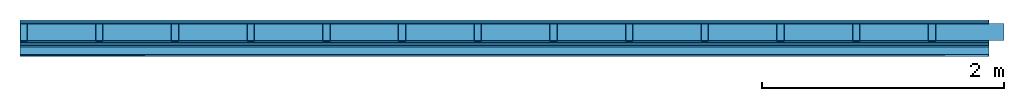
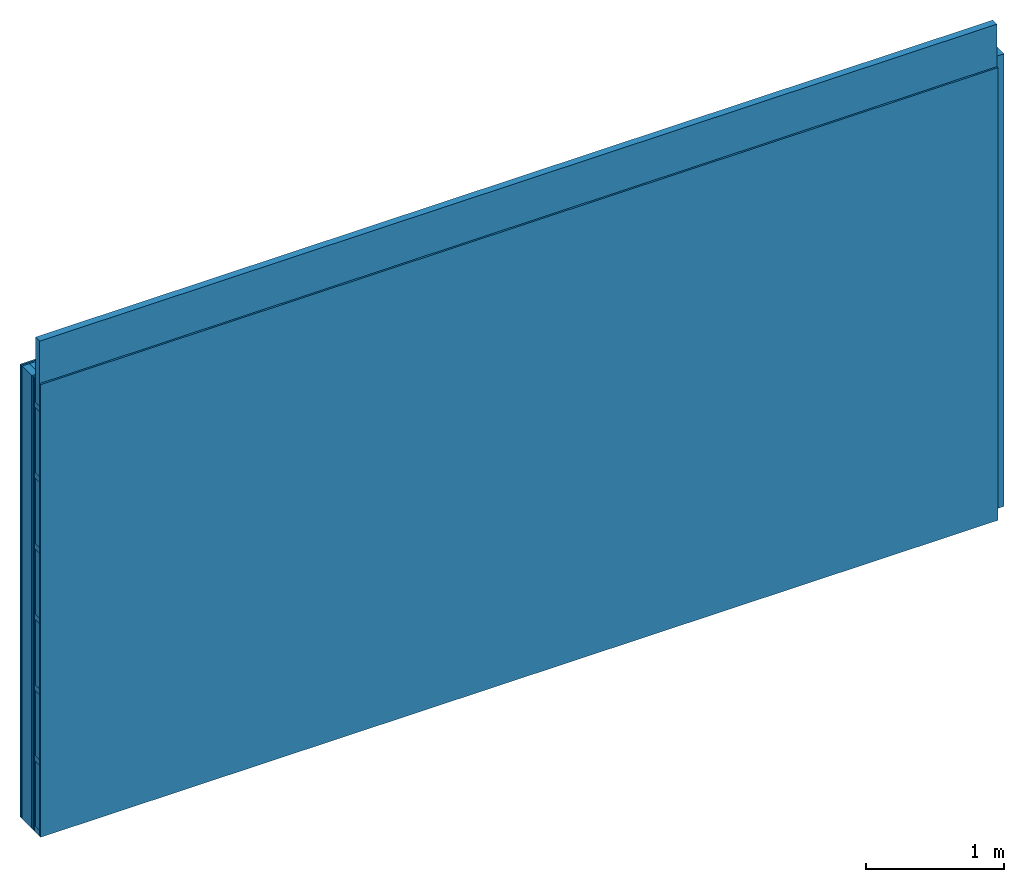
# One storey: 6 plates, 4 members, 1 element without a shape of its own.
"""IFC4 building model written with IfcOpenShell, lengths in metres."""

from ifc_helpers import new_model, si_unit, derived_unit, direction, frame, frame_2d, origin, origin_with_axes, place, context, project, spatial, rectangle, extrude, material, layer, layer_set, type_object, element, aggregate, save


model = new_model("IFC4")

# Units and contexts
plan_context = context("Plan", 3, precision=1e-05, world=origin(), true_north=direction((0.0, 1.0)))
model_context = context("Model", 3, precision=1e-05, world=origin(), true_north=direction((0.0, 1.0)))
ifc_project = project(units=[si_unit("LENGTHUNIT", "METRE"), derived_unit("SOUNDPRESSUREUNIT", [(si_unit("PRESSUREUNIT", "PASCAL", prefix="MICRO"), 0)]), si_unit("ENERGYUNIT", "JOULE", prefix="MEGA"), si_unit("MASSUNIT", "GRAM", prefix="KILO"), derived_unit("THERMALTRANSMITTANCEUNIT", [(si_unit("POWERUNIT", "WATT"), 1), (si_unit("AREAUNIT", "SQUARE_METRE"), -1), (si_unit("THERMODYNAMICTEMPERATUREUNIT", "KELVIN"), -1)]), derived_unit("AREADENSITYUNIT", [(si_unit("MASSUNIT", "GRAM", prefix="KILO"), 1), (si_unit("AREAUNIT", "SQUARE_METRE"), -1)]), derived_unit("USERDEFINED", [(si_unit("ENERGYUNIT", "JOULE", prefix="MEGA"), 1), (si_unit("AREAUNIT", "SQUARE_METRE"), -1)])], contexts=[plan_context, model_context])

# Site, building, storey
site = spatial("IfcSite", under=ifc_project)
building_placement = place(None, origin())
building = spatial("IfcBuilding", under=site, at=building_placement)
storey_placement = place(building_placement, origin())
storey = spatial("IfcBuildingStorey", under=building, at=storey_placement)

# Wall, members, plates
ifc_material_1 = material(Name="Glued joints")
ifc_layer_1 = layer(ifc_material_1, 0.0, Name="Surface")
ifc_material_2 = material(Category="03.007")
ifc_layer_2 = layer(ifc_material_2, 0.015, Name="2nd layer")
ifc_layer_3 = layer(ifc_material_2, 0.015, Name="1st layer")
ifc_material_3 = material(Name="of the art")
ifc_layer_4 = layer(ifc_material_3, 0.0, Name="Bond")
ifc_layer_5 = layer(None, 0.14, Name="Support")
ifc_layer_6 = layer(ifc_material_3, 0.0, Name="Bond")
ifc_layer_7 = layer(ifc_material_2, 0.015, Name="1st layer")
ifc_layer_8 = layer(ifc_material_2, 0.015, Name="2nd layer")
ifc_material_4 = material(Name="Air")
ifc_layer_9 = layer(ifc_material_4, 0.01, Name="Coupling")
ifc_layer_10 = layer(None, 0.075, Name="Battens / profiles")
ifc_layer_11 = layer(ifc_material_2, 0.015, Name="Covering 1st layer")
ifc_layer_12 = layer(ifc_material_1, 0.0, Name="Surface")
ifc_layer_set = layer_set([ifc_layer_1, ifc_layer_2, ifc_layer_3, ifc_layer_4, ifc_layer_5, ifc_layer_6, ifc_layer_7, ifc_layer_8, ifc_layer_9, ifc_layer_10, ifc_layer_11, ifc_layer_12])
wall_type = type_object("IfcWallType", Name="C0096", PredefinedType="NOTDEFINED", material=ifc_layer_set)
wall_placement = place(None, frame((0.0, 0.0, 0.0), z_axis=(0.0, -1.0, 0.0), x_axis=(1.0, 0.0, 0.0)))
wall = element("IfcWall", 1, at=wall_placement, inside=storey, type_object=wall_type, material=ifc_layer_set, Name="Wall #1")
ifc_material_5 = material()
member_1_placement = place(wall_placement, origin())
member_1 = element("IfcMember", 2, at=member_1_placement, material=ifc_material_5, Name="Support", context=plan_context, shape_type="SweptSolid", body=[
    extrude(rectangle(XDim=0.06, YDim=0.14, at=frame_2d((0.03, 0.07), x_axis=(1.0, 0.0))), frame((0.0, 4.0, 0.03), z_axis=(0.0, -1.0, 0.0), x_axis=(1.0, 0.0, 0.0)), (0.0, 0.0, 1.0), 4.0),
    extrude(rectangle(XDim=0.06, YDim=0.14, at=frame_2d((0.03, 0.07), x_axis=(1.0, 0.0))), frame((0.625, 4.0, 0.03), z_axis=(0.0, -1.0, 0.0), x_axis=(1.0, 0.0, 0.0)), (0.0, 0.0, 1.0), 4.0),
    extrude(rectangle(XDim=0.06, YDim=0.14, at=frame_2d((0.03, 0.07), x_axis=(1.0, 0.0))), frame((1.25, 4.0, 0.03), z_axis=(0.0, -1.0, 0.0), x_axis=(1.0, 0.0, 0.0)), (0.0, 0.0, 1.0), 4.0),
    extrude(rectangle(XDim=0.06, YDim=0.14, at=frame_2d((0.03, 0.07), x_axis=(1.0, 0.0))), frame((1.875, 4.0, 0.03), z_axis=(0.0, -1.0, 0.0), x_axis=(1.0, 0.0, 0.0)), (0.0, 0.0, 1.0), 4.0),
    extrude(rectangle(XDim=0.06, YDim=0.14, at=frame_2d((0.03, 0.07), x_axis=(1.0, 0.0))), frame((2.5, 4.0, 0.03), z_axis=(0.0, -1.0, 0.0), x_axis=(1.0, 0.0, 0.0)), (0.0, 0.0, 1.0), 4.0),
    extrude(rectangle(XDim=0.06, YDim=0.14, at=frame_2d((0.03, 0.07), x_axis=(1.0, 0.0))), frame((3.125, 4.0, 0.03), z_axis=(0.0, -1.0, 0.0), x_axis=(1.0, 0.0, 0.0)), (0.0, 0.0, 1.0), 4.0),
    extrude(rectangle(XDim=0.06, YDim=0.14, at=frame_2d((0.03, 0.07), x_axis=(1.0, 0.0))), frame((3.75, 4.0, 0.03), z_axis=(0.0, -1.0, 0.0), x_axis=(1.0, 0.0, 0.0)), (0.0, 0.0, 1.0), 4.0),
    extrude(rectangle(XDim=0.06, YDim=0.14, at=frame_2d((0.03, 0.07), x_axis=(1.0, 0.0))), frame((4.375, 4.0, 0.03), z_axis=(0.0, -1.0, 0.0), x_axis=(1.0, 0.0, 0.0)), (0.0, 0.0, 1.0), 4.0),
    extrude(rectangle(XDim=0.06, YDim=0.14, at=frame_2d((0.03, 0.07), x_axis=(1.0, 0.0))), frame((5.0, 4.0, 0.03), z_axis=(0.0, -1.0, 0.0), x_axis=(1.0, 0.0, 0.0)), (0.0, 0.0, 1.0), 4.0),
    extrude(rectangle(XDim=0.06, YDim=0.14, at=frame_2d((0.03, 0.07), x_axis=(1.0, 0.0))), frame((5.625, 4.0, 0.03), z_axis=(0.0, -1.0, 0.0), x_axis=(1.0, 0.0, 0.0)), (0.0, 0.0, 1.0), 4.0),
    extrude(rectangle(XDim=0.06, YDim=0.14, at=frame_2d((0.03, 0.07), x_axis=(1.0, 0.0))), frame((6.25, 4.0, 0.03), z_axis=(0.0, -1.0, 0.0), x_axis=(1.0, 0.0, 0.0)), (0.0, 0.0, 1.0), 4.0),
    extrude(rectangle(XDim=0.06, YDim=0.14, at=frame_2d((0.03, 0.07), x_axis=(1.0, 0.0))), frame((6.875, 4.0, 0.03), z_axis=(0.0, -1.0, 0.0), x_axis=(1.0, 0.0, 0.0)), (0.0, 0.0, 1.0), 4.0),
    extrude(rectangle(XDim=0.06, YDim=0.14, at=frame_2d((0.03, 0.07), x_axis=(1.0, 0.0))), frame((7.5, 4.0, 0.03), z_axis=(0.0, -1.0, 0.0), x_axis=(1.0, 0.0, 0.0)), (0.0, 0.0, 1.0), 4.0),
])
ifc_material_6 = material()
member_2_placement = place(wall_placement, origin())
member_2 = element("IfcMember", 3, at=member_2_placement, material=ifc_material_6, Name="Cavity", context=plan_context, shape_type="SweptSolid", body=[
    extrude(rectangle(XDim=0.565, YDim=0.14, at=frame_2d((0.2825, 0.07), x_axis=(1.0, 0.0))), frame((0.06, 4.0, 0.03), z_axis=(0.0, -1.0, 0.0), x_axis=(1.0, 0.0, 0.0)), (0.0, 0.0, 1.0), 4.0),
    extrude(rectangle(XDim=0.565, YDim=0.14, at=frame_2d((0.2825, 0.07), x_axis=(1.0, 0.0))), frame((0.685, 4.0, 0.03), z_axis=(0.0, -1.0, 0.0), x_axis=(1.0, 0.0, 0.0)), (0.0, 0.0, 1.0), 4.0),
    extrude(rectangle(XDim=0.565, YDim=0.14, at=frame_2d((0.2825, 0.07), x_axis=(1.0, 0.0))), frame((1.31, 4.0, 0.03), z_axis=(0.0, -1.0, 0.0), x_axis=(1.0, 0.0, 0.0)), (0.0, 0.0, 1.0), 4.0),
    extrude(rectangle(XDim=0.565, YDim=0.14, at=frame_2d((0.2825, 0.07), x_axis=(1.0, 0.0))), frame((1.935, 4.0, 0.03), z_axis=(0.0, -1.0, 0.0), x_axis=(1.0, 0.0, 0.0)), (0.0, 0.0, 1.0), 4.0),
    extrude(rectangle(XDim=0.565, YDim=0.14, at=frame_2d((0.2825, 0.07), x_axis=(1.0, 0.0))), frame((2.56, 4.0, 0.03), z_axis=(0.0, -1.0, 0.0), x_axis=(1.0, 0.0, 0.0)), (0.0, 0.0, 1.0), 4.0),
    extrude(rectangle(XDim=0.565, YDim=0.14, at=frame_2d((0.2825, 0.07), x_axis=(1.0, 0.0))), frame((3.185, 4.0, 0.03), z_axis=(0.0, -1.0, 0.0), x_axis=(1.0, 0.0, 0.0)), (0.0, 0.0, 1.0), 4.0),
    extrude(rectangle(XDim=0.565, YDim=0.14, at=frame_2d((0.2825, 0.07), x_axis=(1.0, 0.0))), frame((3.81, 4.0, 0.03), z_axis=(0.0, -1.0, 0.0), x_axis=(1.0, 0.0, 0.0)), (0.0, 0.0, 1.0), 4.0),
    extrude(rectangle(XDim=0.565, YDim=0.14, at=frame_2d((0.2825, 0.07), x_axis=(1.0, 0.0))), frame((4.435, 4.0, 0.03), z_axis=(0.0, -1.0, 0.0), x_axis=(1.0, 0.0, 0.0)), (0.0, 0.0, 1.0), 4.0),
    extrude(rectangle(XDim=0.565, YDim=0.14, at=frame_2d((0.2825, 0.07), x_axis=(1.0, 0.0))), frame((5.06, 4.0, 0.03), z_axis=(0.0, -1.0, 0.0), x_axis=(1.0, 0.0, 0.0)), (0.0, 0.0, 1.0), 4.0),
    extrude(rectangle(XDim=0.565, YDim=0.14, at=frame_2d((0.2825, 0.07), x_axis=(1.0, 0.0))), frame((5.685, 4.0, 0.03), z_axis=(0.0, -1.0, 0.0), x_axis=(1.0, 0.0, 0.0)), (0.0, 0.0, 1.0), 4.0),
    extrude(rectangle(XDim=0.565, YDim=0.14, at=frame_2d((0.2825, 0.07), x_axis=(1.0, 0.0))), frame((6.31, 4.0, 0.03), z_axis=(0.0, -1.0, 0.0), x_axis=(1.0, 0.0, 0.0)), (0.0, 0.0, 1.0), 4.0),
    extrude(rectangle(XDim=0.565, YDim=0.14, at=frame_2d((0.2825, 0.07), x_axis=(1.0, 0.0))), frame((6.935, 4.0, 0.03), z_axis=(0.0, -1.0, 0.0), x_axis=(1.0, 0.0, 0.0)), (0.0, 0.0, 1.0), 4.0),
    extrude(rectangle(XDim=0.565, YDim=0.14, at=frame_2d((0.2825, 0.07), x_axis=(1.0, 0.0))), frame((7.56, 4.0, 0.03), z_axis=(0.0, -1.0, 0.0), x_axis=(1.0, 0.0, 0.0)), (0.0, 0.0, 1.0), 4.0),
])
ifc_material_7 = material()
member_3_placement = place(wall_placement, origin())
member_3 = element("IfcMember", 4, at=member_3_placement, material=ifc_material_7, Name="Battens / profiles", context=plan_context, shape_type="SweptSolid", body=[
    extrude(rectangle(XDim=0.05, YDim=0.075, at=frame_2d((0.025, 0.0375), x_axis=(1.0, 0.0))), frame((0.0, 0.0, 0.21), z_axis=(1.0, 0.0, 0.0), x_axis=(0.0, 1.0, 0.0)), (0.0, 0.0, 1.0), 8.0),
    extrude(rectangle(XDim=0.05, YDim=0.075, at=frame_2d((0.025, 0.0375), x_axis=(1.0, 0.0))), frame((0.0, 0.625, 0.21), z_axis=(1.0, 0.0, 0.0), x_axis=(0.0, 1.0, 0.0)), (0.0, 0.0, 1.0), 8.0),
    extrude(rectangle(XDim=0.05, YDim=0.075, at=frame_2d((0.025, 0.0375), x_axis=(1.0, 0.0))), frame((0.0, 1.25, 0.21), z_axis=(1.0, 0.0, 0.0), x_axis=(0.0, 1.0, 0.0)), (0.0, 0.0, 1.0), 8.0),
    extrude(rectangle(XDim=0.05, YDim=0.075, at=frame_2d((0.025, 0.0375), x_axis=(1.0, 0.0))), frame((0.0, 1.875, 0.21), z_axis=(1.0, 0.0, 0.0), x_axis=(0.0, 1.0, 0.0)), (0.0, 0.0, 1.0), 8.0),
    extrude(rectangle(XDim=0.05, YDim=0.075, at=frame_2d((0.025, 0.0375), x_axis=(1.0, 0.0))), frame((0.0, 2.5, 0.21), z_axis=(1.0, 0.0, 0.0), x_axis=(0.0, 1.0, 0.0)), (0.0, 0.0, 1.0), 8.0),
    extrude(rectangle(XDim=0.05, YDim=0.075, at=frame_2d((0.025, 0.0375), x_axis=(1.0, 0.0))), frame((0.0, 3.125, 0.21), z_axis=(1.0, 0.0, 0.0), x_axis=(0.0, 1.0, 0.0)), (0.0, 0.0, 1.0), 8.0),
    extrude(rectangle(XDim=0.05, YDim=0.075, at=frame_2d((0.025, 0.0375), x_axis=(1.0, 0.0))), frame((0.0, 3.75, 0.21), z_axis=(1.0, 0.0, 0.0), x_axis=(0.0, 1.0, 0.0)), (0.0, 0.0, 1.0), 8.0),
])
member_4_placement = place(wall_placement, origin())
member_4 = element("IfcMember", 5, at=member_4_placement, material=ifc_material_6, Name="Cavity", context=plan_context, shape_type="SweptSolid", body=[
    extrude(rectangle(XDim=0.575, YDim=0.06, at=frame_2d((0.2875, 0.03), x_axis=(1.0, 0.0))), frame((0.0, 0.05, 0.225), z_axis=(1.0, 0.0, 0.0), x_axis=(0.0, 1.0, 0.0)), (0.0, 0.0, 1.0), 8.0),
    extrude(rectangle(XDim=0.575, YDim=0.06, at=frame_2d((0.2875, 0.03), x_axis=(1.0, 0.0))), frame((0.0, 0.675, 0.225), z_axis=(1.0, 0.0, 0.0), x_axis=(0.0, 1.0, 0.0)), (0.0, 0.0, 1.0), 8.0),
    extrude(rectangle(XDim=0.575, YDim=0.06, at=frame_2d((0.2875, 0.03), x_axis=(1.0, 0.0))), frame((0.0, 1.3, 0.225), z_axis=(1.0, 0.0, 0.0), x_axis=(0.0, 1.0, 0.0)), (0.0, 0.0, 1.0), 8.0),
    extrude(rectangle(XDim=0.575, YDim=0.06, at=frame_2d((0.2875, 0.03), x_axis=(1.0, 0.0))), frame((0.0, 1.925, 0.225), z_axis=(1.0, 0.0, 0.0), x_axis=(0.0, 1.0, 0.0)), (0.0, 0.0, 1.0), 8.0),
    extrude(rectangle(XDim=0.575, YDim=0.06, at=frame_2d((0.2875, 0.03), x_axis=(1.0, 0.0))), frame((0.0, 2.55, 0.225), z_axis=(1.0, 0.0, 0.0), x_axis=(0.0, 1.0, 0.0)), (0.0, 0.0, 1.0), 8.0),
    extrude(rectangle(XDim=0.575, YDim=0.06, at=frame_2d((0.2875, 0.03), x_axis=(1.0, 0.0))), frame((0.0, 3.175, 0.225), z_axis=(1.0, 0.0, 0.0), x_axis=(0.0, 1.0, 0.0)), (0.0, 0.0, 1.0), 8.0),
    extrude(rectangle(XDim=0.575, YDim=0.06, at=frame_2d((0.2875, 0.03), x_axis=(1.0, 0.0))), frame((0.0, 3.8, 0.225), z_axis=(1.0, 0.0, 0.0), x_axis=(0.0, 1.0, 0.0)), (0.0, 0.0, 1.0), 8.0),
])
plate_1_placement = place(wall_placement, origin())
plate_1 = element("IfcPlate", 6, at=plate_1_placement, material=ifc_material_2, Name="2nd layer", context=plan_context, shape_type="SweptSolid", body=[
    extrude(rectangle(XDim=8.0, YDim=4.0, at=frame_2d((4.0, 2.0), x_axis=(1.0, 0.0))), origin_with_axes(), (0.0, 0.0, 1.0), 0.015),
])
plate_2_placement = place(wall_placement, origin())
plate_2 = element("IfcPlate", 7, at=plate_2_placement, material=ifc_material_2, Name="1st layer", context=plan_context, shape_type="SweptSolid", body=[
    extrude(rectangle(XDim=8.0, YDim=4.0, at=frame_2d((4.0, 2.0), x_axis=(1.0, 0.0))), frame((0.0, 0.0, 0.015), z_axis=(0.0, 0.0, 1.0), x_axis=(1.0, 0.0, 0.0)), (0.0, 0.0, 1.0), 0.015),
])
plate_3_placement = place(wall_placement, origin())
plate_3 = element("IfcPlate", 8, at=plate_3_placement, material=ifc_material_2, Name="1st layer", context=plan_context, shape_type="SweptSolid", body=[
    extrude(rectangle(XDim=8.0, YDim=4.0, at=frame_2d((4.0, 2.0), x_axis=(1.0, 0.0))), frame((0.0, 0.0, 0.17), z_axis=(0.0, 0.0, 1.0), x_axis=(1.0, 0.0, 0.0)), (0.0, 0.0, 1.0), 0.015),
])
plate_4_placement = place(wall_placement, origin())
plate_4 = element("IfcPlate", 9, at=plate_4_placement, material=ifc_material_2, Name="2nd layer", context=plan_context, shape_type="SweptSolid", body=[
    extrude(rectangle(XDim=8.0, YDim=4.0, at=frame_2d((4.0, 2.0), x_axis=(1.0, 0.0))), frame((0.0, 0.0, 0.185), z_axis=(0.0, 0.0, 1.0), x_axis=(1.0, 0.0, 0.0)), (0.0, 0.0, 1.0), 0.015),
])
plate_5_placement = place(wall_placement, origin())
plate_5 = element("IfcPlate", 10, at=plate_5_placement, material=ifc_material_4, Name="Coupling", context=plan_context, shape_type="SweptSolid", body=[
    extrude(rectangle(XDim=8.0, YDim=4.0, at=frame_2d((4.0, 2.0), x_axis=(1.0, 0.0))), frame((0.0, 0.0, 0.2), z_axis=(0.0, 0.0, 1.0), x_axis=(1.0, 0.0, 0.0)), (0.0, 0.0, 1.0), 0.01),
])
plate_6_placement = place(wall_placement, origin())
plate_6 = element("IfcPlate", 11, at=plate_6_placement, material=ifc_material_2, Name="Covering 1st layer", context=plan_context, shape_type="SweptSolid", body=[
    extrude(rectangle(XDim=8.0, YDim=4.0, at=frame_2d((4.0, 2.0), x_axis=(1.0, 0.0))), frame((0.0, 0.0, 0.285), z_axis=(0.0, 0.0, 1.0), x_axis=(1.0, 0.0, 0.0)), (0.0, 0.0, 1.0), 0.015),
])
aggregate(wall, [plate_1, plate_2, member_1, member_2, plate_3, plate_4, plate_5, member_3, member_4, plate_6])

save(model, "model.ifc")
